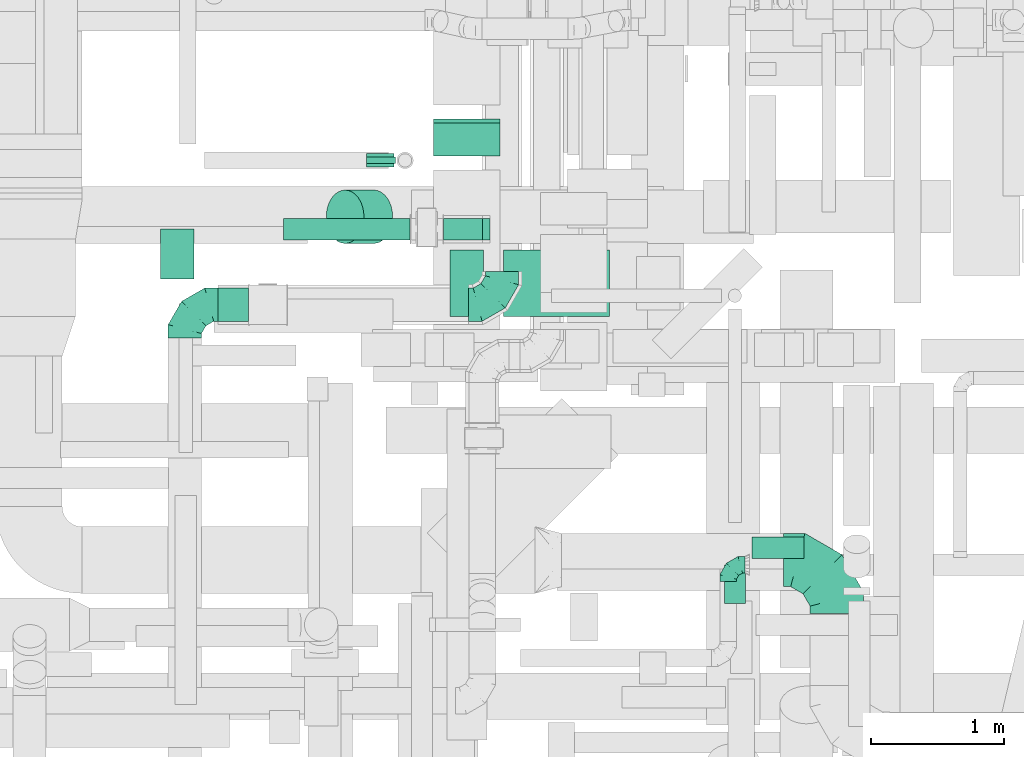
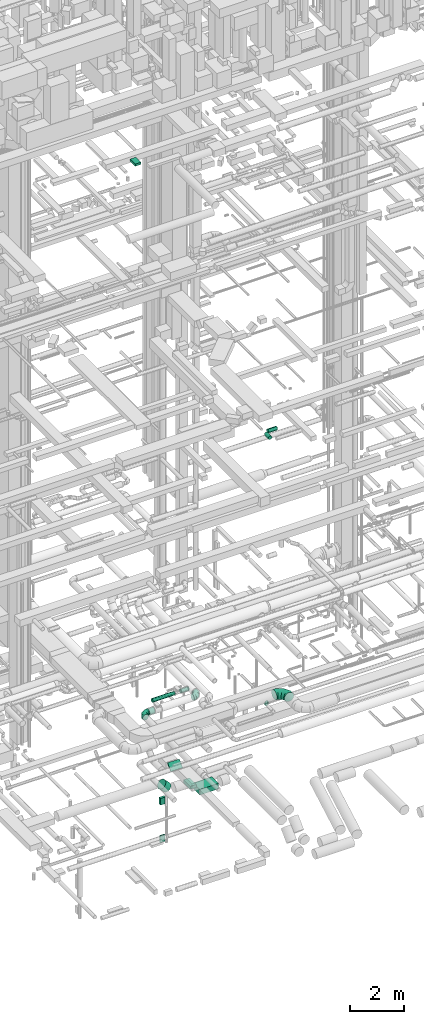
# One storey, part 166 of 337: 12 flow segments, 5 flow fittings.
"""IFC2X3 building model written with IfcOpenShell, lengths in millimetres."""

from ifc_helpers import new_model, entity, si_unit, converted_unit, derived_unit, direction, frame, origin, origin_2d_with_axis, place, context, subcontext, project, spatial, rectangle, circle, extrude, faceted_brep, source, transform, mapped, material, type_object, type_shapes, element, save


model = new_model("IFC2X3")

# Units and contexts
model_context = context("Model", 3, precision=0.01, world=origin(), true_north=direction((6.12303176911189e-17, 1.0)))
body_context = subcontext(model_context, "Body", "Model", "MODEL_VIEW")
ifc_project = project(units=[si_unit("LENGTHUNIT", "METRE", prefix="MILLI"), si_unit("AREAUNIT", "SQUARE_METRE"), si_unit("VOLUMEUNIT", "CUBIC_METRE"), converted_unit("PLANEANGLEUNIT", "DEGREE", entity("IfcRatioMeasure", 0.0174532925199433), si_unit("PLANEANGLEUNIT", "RADIAN"), dimensions=[0, 0, 0, 0, 0, 0, 0]), si_unit("MASSUNIT", "GRAM", prefix="KILO"), derived_unit("MASSDENSITYUNIT", [(si_unit("MASSUNIT", "GRAM", prefix="KILO"), 1), (si_unit("LENGTHUNIT", "METRE"), -3)]), derived_unit("MOMENTOFINERTIAUNIT", [(si_unit("LENGTHUNIT", "METRE"), 4)]), si_unit("TIMEUNIT", "SECOND"), si_unit("FREQUENCYUNIT", "HERTZ"), si_unit("THERMODYNAMICTEMPERATUREUNIT", "DEGREE_CELSIUS"), derived_unit("THERMALTRANSMITTANCEUNIT", [(si_unit("MASSUNIT", "GRAM", prefix="KILO"), 1), (si_unit("THERMODYNAMICTEMPERATUREUNIT", "KELVIN"), -1), (si_unit("TIMEUNIT", "SECOND"), -3)]), derived_unit("VOLUMETRICFLOWRATEUNIT", [(si_unit("LENGTHUNIT", "METRE"), 3), (si_unit("TIMEUNIT", "SECOND"), -1)]), derived_unit("MASSFLOWRATEUNIT", [(si_unit("MASSUNIT", "GRAM", prefix="KILO"), 1), (si_unit("TIMEUNIT", "SECOND"), -1)]), derived_unit("ROTATIONALFREQUENCYUNIT", [(si_unit("TIMEUNIT", "SECOND"), -1)]), si_unit("ELECTRICCURRENTUNIT", "AMPERE"), si_unit("ELECTRICVOLTAGEUNIT", "VOLT"), si_unit("POWERUNIT", "WATT"), si_unit("FORCEUNIT", "NEWTON", prefix="KILO"), si_unit("ILLUMINANCEUNIT", "LUX"), si_unit("LUMINOUSFLUXUNIT", "LUMEN"), si_unit("LUMINOUSINTENSITYUNIT", "CANDELA"), derived_unit("USERDEFINED", [(si_unit("MASSUNIT", "GRAM", prefix="KILO"), -1), (si_unit("LENGTHUNIT", "METRE"), -2), (si_unit("TIMEUNIT", "SECOND"), 3), (si_unit("LUMINOUSFLUXUNIT", "LUMEN"), 1)]), derived_unit("LINEARVELOCITYUNIT", [(si_unit("LENGTHUNIT", "METRE"), 1), (si_unit("TIMEUNIT", "SECOND"), -1)]), si_unit("PRESSUREUNIT", "PASCAL"), derived_unit("USERDEFINED", [(si_unit("LENGTHUNIT", "METRE"), -2), (si_unit("MASSUNIT", "GRAM", prefix="KILO"), 1), (si_unit("TIMEUNIT", "SECOND"), -2)]), derived_unit("LINEARFORCEUNIT", [(si_unit("MASSUNIT", "GRAM", prefix="KILO"), 1), (si_unit("LENGTHUNIT", "METRE"), 1), (si_unit("TIMEUNIT", "SECOND"), -2), (si_unit("LENGTHUNIT", "METRE"), -1)]), derived_unit("PLANARFORCEUNIT", [(si_unit("MASSUNIT", "GRAM", prefix="KILO"), 1), (si_unit("LENGTHUNIT", "METRE"), 1), (si_unit("TIMEUNIT", "SECOND"), -2), (si_unit("LENGTHUNIT", "METRE"), -2)])], contexts=[model_context])

# Site, building, storey
site_placement = place(None, origin())
site = spatial("IfcSite", under=ifc_project, at=site_placement, CompositionType="ELEMENT")
building_placement = place(site_placement, origin())
building = spatial("IfcBuilding", under=site, at=building_placement, CompositionType="ELEMENT")
storey_placement = place(building_placement, origin())
storey = spatial("IfcBuildingStorey", under=building, at=storey_placement, CompositionType="ELEMENT", Elevation=0.0)

# Flow segments
duct_segment_type_1 = type_object("IfcDuctSegmentType", PredefinedType="NOTDEFINED")
flow_segment_1_placement = place(storey_placement, frame((49213.6, 7180.9, -948.55)))
element("IfcFlowSegment", 1, at=flow_segment_1_placement, inside=storey, type_object=duct_segment_type_1, context=body_context, shape_type="SweptSolid", body=[
    extrude(rectangle(XDim=41.888132824211, YDim=350.000000000001, at=origin_2d_with_axis()), frame((0.0, 138.55, 138.55), z_axis=(1.0, 0.0, 0.0), x_axis=(0.0, -0.707106781186528, 0.707106781186567)), (0.0, 0.0, 1.0), 500.000000000016),
])
flow_segment_2_placement = place(storey_placement, frame((49338.6, 5973.55, -1025.0)))
element("IfcFlowSegment", 2, at=flow_segment_2_placement, inside=storey, type_object=duct_segment_type_1, context=body_context, shape_type="SweptSolid", body=[
    extrude(rectangle(XDim=500.0, YDim=250.000000000004, at=origin_2d_with_axis()), frame((125.0, 250.0, 0.0), z_axis=(0.0, 0.0, 1.0), x_axis=(0.0, -1.0, 0.0)), (0.0, 0.0, 1.0), 129.99999999994),
])
flow_segment_3_placement = place(storey_placement, frame((49738.6, 5973.55, -1425.0)))
element("IfcFlowSegment", 3, at=flow_segment_3_placement, inside=storey, type_object=duct_segment_type_1, context=body_context, shape_type="SweptSolid", body=[
    extrude(rectangle(XDim=797.245327746324, YDim=500.0, at=origin_2d_with_axis()), frame((398.62, 250.0, 0.0)), (0.0, 0.0, 1.0), 250.0),
])
flow_segment_4_placement = place(storey_placement, frame((48711.88, 7096.24, -2200.0)))
element("IfcFlowSegment", 4, at=flow_segment_4_placement, inside=storey, type_object=duct_segment_type_1, context=body_context, shape_type="SweptSolid", body=[
    extrude(rectangle(XDim=204.999967249919, YDim=100.0, at=origin_2d_with_axis()), frame((102.5, 50.0, 0.0), z_axis=(0.0, 0.0, 1.0), x_axis=(-1.0, 0.0, 0.0)), (0.0, 0.0, 1.0), 300.0),
])
flow_segment_5_placement = place(storey_placement, frame((48711.74, 7121.24, -3900.0)))
element("IfcFlowSegment", 5, at=flow_segment_5_placement, inside=storey, type_object=duct_segment_type_1, context=body_context, shape_type="SweptSolid", body=[
    extrude(rectangle(XDim=217.638826253178, YDim=49.9999999999995, at=origin_2d_with_axis()), frame((108.82, 25.0, 0.0), z_axis=(0.0, 0.0, 1.0), x_axis=(-1.0, 0.0, 0.0)), (0.0, 0.0, 1.0), 300.0),
])
flow_segment_6_placement = place(storey_placement, frame((47164.17, 6255.79, 27500.0)))
element("IfcFlowSegment", 6, at=flow_segment_6_placement, inside=storey, type_object=duct_segment_type_1, context=body_context, shape_type="SweptSolid", body=[
    extrude(rectangle(XDim=374.199999998891, YDim=250.000000000004, at=origin_2d_with_axis()), frame((125.0, 187.1, 0.0), z_axis=(0.0, 0.0, 1.0), x_axis=(0.0, -1.0, 0.0)), (0.0, 0.0, 1.0), 100.000000000003),
])
duct_segment_type_2 = type_object("IfcDuctSegmentType", PredefinedType="NOTDEFINED")
flow_segment_7_placement = place(storey_placement, frame((51394.41, 3818.15, 15218.4)))
element("IfcFlowSegment", 7, at=flow_segment_7_placement, inside=storey, type_object=duct_segment_type_2, context=body_context, shape_type="SweptSolid", body=[
    extrude(circle(Radius=80.0, at=origin_2d_with_axis()), frame((81.6, 0.0, 81.6), z_axis=(0.0, 1.0, 0.0), x_axis=(1.0, 0.0, 0.0)), (0.0, 0.0, 1.0), 290.000000000021),
])
flow_segment_8_placement = place(storey_placement, frame((51606.01, 4156.55, 15218.4)))
element("IfcFlowSegment", 8, at=flow_segment_8_placement, inside=storey, type_object=duct_segment_type_2, context=body_context, shape_type="SweptSolid", body=[
    extrude(circle(Radius=80.0, at=origin_2d_with_axis()), frame((0.0, 81.6, 81.6), z_axis=(1.0, 0.0, 0.0), x_axis=(0.0, -1.0, 0.0)), (0.0, 0.0, 1.0), 390.000000000015),
])
flow_segment_9_placement = place(storey_placement, frame((47596.39, 5936.56, 2873.4)))
element("IfcFlowSegment", 9, at=flow_segment_9_placement, inside=storey, type_object=duct_segment_type_2, context=body_context, shape_type="SweptSolid", body=[
    extrude(circle(Radius=125.0, at=origin_2d_with_axis()), frame((0.0, 126.6, 126.6), z_axis=(1.0, 0.0, 0.0), x_axis=(0.0, 1.0, 0.0)), (0.0, 0.0, 1.0), 228.606797780962),
])
flow_segment_10_placement = place(storey_placement, frame((48406.52, 6521.49, -1325.86)))
element("IfcFlowSegment", 10, at=flow_segment_10_placement, inside=storey, type_object=duct_segment_type_2, context=body_context, shape_type="SweptSolid", body=[
    extrude(circle(Radius=200.0, at=origin_2d_with_axis()), frame((358.7, 201.6, 143.02), z_axis=(-0.707106781186547, 0.0, 0.707106781186548), x_axis=(0.0, -1.0, 0.0)), (0.0, 0.0, 1.0), 305.025253169392),
])
flow_segment_11_placement = place(storey_placement, frame((48088.92, 6547.83, 2918.4)))
element("IfcFlowSegment", 11, at=flow_segment_11_placement, inside=storey, type_object=duct_segment_type_2, context=body_context, shape_type="SweptSolid", body=[
    extrude(circle(Radius=80.0, at=origin_2d_with_axis()), frame((0.0, 81.6, 81.6), z_axis=(1.0, 0.0, 0.0), x_axis=(0.0, 1.0, 0.0)), (0.0, 0.0, 1.0), 949.341560000641),
])
flow_segment_12_placement = place(storey_placement, frame((49288.27, 6547.83, 2918.4)))
element("IfcFlowSegment", 12, at=flow_segment_12_placement, inside=storey, type_object=duct_segment_type_2, context=body_context, shape_type="SweptSolid", body=[
    extrude(circle(Radius=80.0, at=origin_2d_with_axis()), frame((0.0, 81.6, 81.6), z_axis=(1.0, 0.0, 0.0), x_axis=(0.0, 1.0, 0.0)), (0.0, 0.0, 1.0), 294.275379129593),
])

# Flow fittings
ifc_material = material()
duct_fitting_type_1 = type_object("IfcDuctFittingType", PredefinedType="NOTDEFINED", material=ifc_material)
shared_shape_1 = source(origin(), body_context, "Body", "Brep", [
    faceted_brep([(-250.0, 0.0, -125.0), (-250.0, -32.35, -120.74), (-250.0, -62.5, -108.25), (-250.0, -88.39, -88.39), (-250.0, -108.25, -62.5), (-250.0, -120.74, -32.35), (-250.0, -125.0, 0.0), (-250.0, -120.74, 32.35), (-250.0, -108.25, 62.5), (-250.0, -88.39, 88.39), (-250.0, -62.5, 108.25), (-250.0, -32.35, 120.74), (-250.0, 0.0, 125.0), (-250.0, 32.35, 120.74), (-250.0, 62.5, 108.25), (-250.0, 88.39, 88.39), (-250.0, 108.25, 62.5), (-250.0, 120.74, 32.35), (-250.0, 125.0, 0.0), (-250.0, 120.74, -32.35), (-250.0, 108.25, -62.5), (-250.0, 88.39, -88.39), (-250.0, 62.5, -108.25), (-250.0, 32.35, -120.74), (-191.68, 32.35, 120.74), (-199.76, 62.5, 108.25), (-183.01, 0.0, 125.0), (-206.7, 88.39, 88.39), (-215.37, 120.74, 32.35), (-216.51, 125.0, 0.0), (-212.02, 108.25, 62.5), (-212.02, 108.25, -62.5), (-206.7, 88.39, -88.39), (-215.37, 120.74, -32.35), (-191.68, 32.35, -120.74), (-183.01, 0.0, -125.0), (-199.76, 62.5, -108.25), (-174.34, -32.35, -120.74), (-166.27, -62.5, -108.25), (-159.33, -88.39, -88.39), (-154.01, -108.25, -62.5), (-150.66, -120.74, -32.35), (-149.52, -125.0, 0.0), (-150.66, -120.74, 32.35), (-154.01, -108.25, 62.5), (-159.33, -88.39, 88.39), (-166.27, -62.5, 108.25), (-174.34, -32.35, 120.74), (-90.67, 90.67, 120.74), (-112.74, 112.74, 108.25), (-66.99, 66.99, 125.0), (-131.69, 131.69, 88.39), (-146.23, 146.23, 62.5), (-155.38, 155.38, 32.35), (-158.49, 158.49, 0.0), (-155.38, 155.38, -32.35), (-146.23, 146.23, -62.5), (-131.69, 131.69, -88.39), (-90.67, 90.67, -120.74), (-66.99, 66.99, -125.0), (-112.74, 112.74, -108.25), (-43.3, 43.3, -120.74), (-21.23, 21.23, -108.25), (-2.28, 2.28, -88.39), (12.26, -12.26, -62.5), (21.4, -21.4, -32.35), (24.52, -24.52, 0.0), (21.4, -21.4, 32.35), (12.26, -12.26, 62.5), (-2.28, 2.28, 88.39), (-21.23, 21.23, 108.25), (-43.3, 43.3, 120.74), (-32.35, 191.68, 120.74), (-62.5, 199.76, 108.25), (0.0, 183.01, 125.0), (-88.39, 206.7, 88.39), (-108.25, 212.02, 62.5), (-120.74, 215.37, 32.35), (-125.0, 216.51, 0.0), (-120.74, 215.37, -32.35), (-108.25, 212.02, -62.5), (-88.39, 206.7, -88.39), (-32.35, 191.68, -120.74), (0.0, 183.01, -125.0), (-62.5, 199.76, -108.25), (32.35, 174.34, -120.74), (62.5, 166.27, -108.25), (88.39, 159.33, -88.39), (108.25, 154.01, -62.5), (120.74, 150.66, -32.35), (125.0, 149.52, 0.0), (120.74, 150.66, 32.35), (108.25, 154.01, 62.5), (88.39, 159.33, 88.39), (62.5, 166.27, 108.25), (32.35, 174.34, 120.74), (-32.35, 250.0, -120.74), (-62.5, 250.0, -108.25), (-88.39, 250.0, -88.39), (-108.25, 250.0, -62.5), (-120.74, 250.0, -32.35), (-125.0, 250.0, 0.0), (-120.74, 250.0, 32.35), (-108.25, 250.0, 62.5), (-88.39, 250.0, 88.39), (-62.5, 250.0, 108.25), (-32.35, 250.0, 120.74), (0.0, 250.0, 125.0), (32.35, 250.0, 120.74), (62.5, 250.0, 108.25), (88.39, 250.0, 88.39), (108.25, 250.0, 62.5), (120.74, 250.0, 32.35), (125.0, 250.0, 0.0), (120.74, 250.0, -32.35), (108.25, 250.0, -62.5), (88.39, 250.0, -88.39), (62.5, 250.0, -108.25), (32.35, 250.0, -120.74), (0.0, 250.0, -125.0)], [[[0, 1, 2, 3, 4, 5, 6, 7, 8, 9, 10, 11, 12, 13, 14, 15, 16, 17, 18, 19, 20, 21, 22, 23]], [[24, 25, 14, 13]], [[26, 24, 13, 12]], [[14, 25, 27, 15]], [[28, 29, 18, 17]], [[30, 28, 17, 16]], [[15, 27, 30, 16]], [[20, 31, 32, 21]], [[33, 31, 20, 19]], [[18, 29, 33, 19]], [[34, 35, 0, 23]], [[36, 34, 23, 22]], [[21, 32, 36, 22]], [[1, 0, 35, 37]], [[2, 1, 37, 38]], [[38, 39, 3, 2]], [[5, 4, 40, 41]], [[6, 5, 41, 42]], [[39, 40, 4, 3]], [[6, 42, 43, 7]], [[7, 43, 44, 8]], [[8, 44, 45, 9]], [[9, 45, 46, 10]], [[10, 46, 47, 11]], [[26, 12, 11, 47]], [[48, 49, 25, 24]], [[50, 48, 24, 26]], [[27, 25, 49, 51]], [[52, 53, 28, 30]], [[51, 52, 30, 27]], [[29, 28, 53, 54]], [[55, 56, 31, 33]], [[54, 55, 33, 29]], [[32, 31, 56, 57]], [[58, 59, 35, 34]], [[60, 58, 34, 36]], [[57, 60, 36, 32]], [[37, 35, 59, 61]], [[38, 37, 61, 62]], [[39, 38, 62, 63]], [[41, 40, 64, 65]], [[42, 41, 65, 66]], [[63, 64, 40, 39]], [[43, 42, 66, 67]], [[44, 43, 67, 68]], [[68, 69, 45, 44]], [[46, 45, 69, 70]], [[47, 46, 70, 71]], [[26, 47, 71, 50]], [[72, 73, 49, 48]], [[74, 72, 48, 50]], [[51, 49, 73, 75]], [[76, 77, 53, 52]], [[75, 76, 52, 51]], [[54, 53, 77, 78]], [[79, 80, 56, 55]], [[78, 79, 55, 54]], [[57, 56, 80, 81]], [[82, 83, 59, 58]], [[84, 82, 58, 60]], [[81, 84, 60, 57]], [[61, 59, 83, 85]], [[62, 61, 85, 86]], [[63, 62, 86, 87]], [[65, 64, 88, 89]], [[66, 65, 89, 90]], [[87, 88, 64, 63]], [[67, 66, 90, 91]], [[68, 67, 91, 92]], [[92, 93, 69, 68]], [[70, 69, 93, 94]], [[71, 70, 94, 95]], [[50, 71, 95, 74]], [[96, 97, 98, 99, 100, 101, 102, 103, 104, 105, 106, 107, 108, 109, 110, 111, 112, 113, 114, 115, 116, 117, 118, 119]], [[72, 74, 107, 106]], [[73, 72, 106, 105]], [[75, 73, 105, 104]], [[77, 76, 103, 102]], [[78, 77, 102, 101]], [[75, 104, 103, 76]], [[78, 101, 100, 79]], [[79, 100, 99, 80]], [[80, 99, 98, 81]], [[84, 97, 96, 82]], [[82, 96, 119, 83]], [[84, 81, 98, 97]], [[83, 119, 118, 85]], [[85, 118, 117, 86]], [[116, 87, 86, 117]], [[88, 115, 114, 89]], [[89, 114, 113, 90]], [[115, 88, 87, 116]], [[91, 90, 113, 112]], [[92, 91, 112, 111]], [[111, 110, 93, 92]], [[95, 94, 109, 108]], [[74, 95, 108, 107]], [[110, 109, 94, 93]]]),
])
type_shapes(duct_fitting_type_1, [shared_shape_1])
flow_fitting_1_placement = place(storey_placement, frame((47346.39, 6063.16, 3000.0), z_axis=(0.0, 0.0, 1.0), x_axis=(-1.0, 0.0, 0.0)))
element("IfcFlowFitting", 13, at=flow_fitting_1_placement, inside=storey, type_object=duct_fitting_type_1, material=ifc_material, context=body_context, shape_type="MappedRepresentation", body=[
    mapped(shared_shape_1, transform((0.0, 0.0, 0.0), scale=1.0)),
])
flow_fitting_2_placement = place(storey_placement, frame((49727.54, 6063.16, 3000.0)))
element("IfcFlowFitting", 14, at=flow_fitting_2_placement, inside=storey, type_object=duct_fitting_type_1, material=ifc_material, context=body_context, shape_type="MappedRepresentation", body=[
    mapped(shared_shape_1, transform((0.0, 0.0, 0.0), scale=1.0)),
])
duct_fitting_type_2 = type_object("IfcDuctFittingType", PredefinedType="NOTDEFINED", material=ifc_material)
shared_shape_2 = source(origin(), body_context, "Body", "Brep", [
    faceted_brep([(-125.0, 0.0, -62.5), (-125.0, -16.18, -60.37), (-125.0, -31.25, -54.13), (-125.0, -44.19, -44.19), (-125.0, -54.13, -31.25), (-125.0, -60.37, -16.18), (-125.0, -62.5, 0.0), (-125.0, -60.37, 16.18), (-125.0, -54.13, 31.25), (-125.0, -44.19, 44.19), (-125.0, -31.25, 54.13), (-125.0, -16.18, 60.37), (-125.0, 0.0, 62.5), (-125.0, 16.18, 60.37), (-125.0, 31.25, 54.13), (-125.0, 44.19, 44.19), (-125.0, 54.13, 31.25), (-125.0, 60.37, 16.18), (-125.0, 62.5, 0.0), (-125.0, 60.37, -16.18), (-125.0, 54.13, -31.25), (-125.0, 44.19, -44.19), (-125.0, 31.25, -54.13), (-125.0, 16.18, -60.37), (-95.84, 16.18, 60.37), (-99.88, 31.25, 54.13), (-91.51, 0.0, 62.5), (-103.35, 44.19, 44.19), (-107.68, 60.37, 16.18), (-108.25, 62.5, 0.0), (-106.01, 54.13, 31.25), (-106.01, 54.13, -31.25), (-103.35, 44.19, -44.19), (-107.68, 60.37, -16.18), (-95.84, 16.18, -60.37), (-91.51, 0.0, -62.5), (-99.88, 31.25, -54.13), (-87.17, -16.18, -60.37), (-83.13, -31.25, -54.13), (-79.66, -44.19, -44.19), (-77.0, -54.13, -31.25), (-75.33, -60.37, -16.18), (-74.76, -62.5, 0.0), (-75.33, -60.37, 16.18), (-77.0, -54.13, 31.25), (-79.66, -44.19, 44.19), (-83.13, -31.25, 54.13), (-87.17, -16.18, 60.37), (-45.34, 45.34, 60.37), (-56.37, 56.37, 54.13), (-33.49, 33.49, 62.5), (-65.85, 65.85, 44.19), (-73.12, 73.12, 31.25), (-77.69, 77.69, 16.18), (-79.25, 79.25, 0.0), (-77.69, 77.69, -16.18), (-73.12, 73.12, -31.25), (-65.85, 65.85, -44.19), (-45.34, 45.34, -60.37), (-33.49, 33.49, -62.5), (-56.37, 56.37, -54.13), (-21.65, 21.65, -60.37), (-10.62, 10.62, -54.13), (-1.14, 1.14, -44.19), (6.13, -6.13, -31.25), (10.7, -10.7, -16.18), (12.26, -12.26, 0.0), (10.7, -10.7, 16.18), (6.13, -6.13, 31.25), (-1.14, 1.14, 44.19), (-10.62, 10.62, 54.13), (-21.65, 21.65, 60.37), (-16.18, 95.84, 60.37), (-31.25, 99.88, 54.13), (0.0, 91.51, 62.5), (-44.19, 103.35, 44.19), (-54.13, 106.01, 31.25), (-60.37, 107.68, 16.18), (-62.5, 108.25, 0.0), (-60.37, 107.68, -16.18), (-54.13, 106.01, -31.25), (-44.19, 103.35, -44.19), (-16.18, 95.84, -60.37), (0.0, 91.51, -62.5), (-31.25, 99.88, -54.13), (16.18, 87.17, -60.37), (31.25, 83.13, -54.13), (44.19, 79.66, -44.19), (54.13, 77.0, -31.25), (60.37, 75.33, -16.18), (62.5, 74.76, 0.0), (60.37, 75.33, 16.18), (54.13, 77.0, 31.25), (44.19, 79.66, 44.19), (31.25, 83.13, 54.13), (16.18, 87.17, 60.37), (-16.18, 125.0, -60.37), (-31.25, 125.0, -54.13), (-44.19, 125.0, -44.19), (-54.13, 125.0, -31.25), (-60.37, 125.0, -16.18), (-62.5, 125.0, 0.0), (-60.37, 125.0, 16.18), (-54.13, 125.0, 31.25), (-44.19, 125.0, 44.19), (-31.25, 125.0, 54.13), (-16.18, 125.0, 60.37), (0.0, 125.0, 62.5), (16.18, 125.0, 60.37), (31.25, 125.0, 54.13), (44.19, 125.0, 44.19), (54.13, 125.0, 31.25), (60.37, 125.0, 16.18), (62.5, 125.0, 0.0), (60.37, 125.0, -16.18), (54.13, 125.0, -31.25), (44.19, 125.0, -44.19), (31.25, 125.0, -54.13), (16.18, 125.0, -60.37), (0.0, 125.0, -62.5)], [[[0, 1, 2, 3, 4, 5, 6, 7, 8, 9, 10, 11, 12, 13, 14, 15, 16, 17, 18, 19, 20, 21, 22, 23]], [[24, 25, 14, 13]], [[26, 24, 13, 12]], [[14, 25, 27, 15]], [[28, 29, 18, 17]], [[30, 28, 17, 16]], [[15, 27, 30, 16]], [[20, 31, 32, 21]], [[33, 31, 20, 19]], [[18, 29, 33, 19]], [[34, 35, 0, 23]], [[36, 34, 23, 22]], [[21, 32, 36, 22]], [[1, 0, 35, 37]], [[2, 1, 37, 38]], [[38, 39, 3, 2]], [[5, 4, 40, 41]], [[6, 5, 41, 42]], [[39, 40, 4, 3]], [[6, 42, 43, 7]], [[7, 43, 44, 8]], [[45, 9, 8, 44]], [[9, 45, 46, 10]], [[10, 46, 47, 11]], [[26, 12, 11, 47]], [[48, 49, 25, 24]], [[50, 48, 24, 26]], [[27, 25, 49, 51]], [[52, 53, 28, 30]], [[51, 52, 30, 27]], [[29, 28, 53, 54]], [[55, 56, 31, 33]], [[54, 55, 33, 29]], [[57, 32, 31, 56]], [[58, 59, 35, 34]], [[60, 58, 34, 36]], [[57, 60, 36, 32]], [[37, 35, 59, 61]], [[38, 37, 61, 62]], [[39, 38, 62, 63]], [[41, 40, 64, 65]], [[42, 41, 65, 66]], [[63, 64, 40, 39]], [[43, 42, 66, 67]], [[44, 43, 67, 68]], [[68, 69, 45, 44]], [[46, 45, 69, 70]], [[47, 46, 70, 71]], [[26, 47, 71, 50]], [[72, 73, 49, 48]], [[74, 72, 48, 50]], [[51, 49, 73, 75]], [[76, 77, 53, 52]], [[75, 76, 52, 51]], [[54, 53, 77, 78]], [[79, 80, 56, 55]], [[78, 79, 55, 54]], [[81, 57, 56, 80]], [[82, 83, 59, 58]], [[84, 82, 58, 60]], [[81, 84, 60, 57]], [[61, 59, 83, 85]], [[62, 61, 85, 86]], [[63, 62, 86, 87]], [[65, 64, 88, 89]], [[66, 65, 89, 90]], [[87, 88, 64, 63]], [[67, 66, 90, 91]], [[68, 67, 91, 92]], [[92, 93, 69, 68]], [[70, 69, 93, 94]], [[71, 70, 94, 95]], [[50, 71, 95, 74]], [[96, 97, 98, 99, 100, 101, 102, 103, 104, 105, 106, 107, 108, 109, 110, 111, 112, 113, 114, 115, 116, 117, 118, 119]], [[72, 74, 107, 106]], [[73, 72, 106, 105]], [[75, 73, 105, 104]], [[77, 76, 103, 102]], [[78, 77, 102, 101]], [[75, 104, 103, 76]], [[78, 101, 100, 79]], [[79, 100, 99, 80]], [[80, 99, 98, 81]], [[96, 119, 83, 82]], [[97, 96, 82, 84]], [[84, 81, 98, 97]], [[83, 119, 118, 85]], [[85, 118, 117, 86]], [[116, 87, 86, 117]], [[88, 115, 114, 89]], [[89, 114, 113, 90]], [[115, 88, 87, 116]], [[91, 90, 113, 112]], [[92, 91, 112, 111]], [[111, 110, 93, 92]], [[95, 94, 109, 108]], [[74, 95, 108, 107]], [[110, 109, 94, 93]]]),
])
type_shapes(duct_fitting_type_2, [shared_shape_2])
flow_fitting_3_placement = place(storey_placement, frame((51425.0, 4110.29, 3250.0), z_axis=(0.0, 0.0, 1.0), x_axis=(-1.0, 0.0, 0.0)))
element("IfcFlowFitting", 15, at=flow_fitting_3_placement, inside=storey, type_object=duct_fitting_type_2, material=ifc_material, context=body_context, shape_type="MappedRepresentation", body=[
    mapped(shared_shape_2, transform((0.0, 0.0, 0.0), scale=1.0)),
])
duct_fitting_type_3 = type_object("IfcDuctFittingType", PredefinedType="NOTDEFINED", material=ifc_material)
shared_shape_3 = source(origin(), body_context, "Body", "Brep", [
    faceted_brep([(-400.0, 0.0, -200.0), (-400.0, -44.5, -194.99), (-400.0, -86.78, -180.19), (-400.0, -124.7, -156.37), (-400.0, -156.37, -124.7), (-400.0, -180.19, -86.78), (-400.0, -194.99, -44.5), (-400.0, -200.0, 0.0), (-400.0, -194.99, 44.5), (-400.0, -180.19, 86.78), (-400.0, -156.37, 124.7), (-400.0, -124.7, 156.37), (-400.0, -86.78, 180.19), (-400.0, -44.5, 194.99), (-400.0, 0.0, 200.0), (-400.0, 44.5, 194.99), (-400.0, 86.78, 180.19), (-400.0, 124.7, 156.37), (-400.0, 156.37, 124.7), (-400.0, 180.19, 86.78), (-400.0, 194.99, 44.5), (-400.0, 200.0, 0.0), (-400.0, 194.99, -44.5), (-400.0, 180.19, -86.78), (-400.0, 156.37, -124.7), (-400.0, 124.7, -156.37), (-400.0, 86.78, -180.19), (-400.0, 44.5, -194.99), (-292.82, 0.0, 200.0), (-304.75, 44.5, 194.99), (-316.07, 86.78, 180.19), (-326.23, 124.7, 156.37), (-334.72, 156.37, 124.7), (-341.1, 180.19, 86.78), (-345.07, 194.99, 44.5), (-346.41, 200.0, 0.0), (-345.07, 194.99, -44.5), (-341.1, 180.19, -86.78), (-334.72, 156.37, -124.7), (-326.23, 124.7, -156.37), (-316.07, 86.78, -180.19), (-304.75, 44.5, -194.99), (-292.82, 0.0, -200.0), (-280.9, -44.5, -194.99), (-269.57, -86.78, -180.19), (-259.41, -124.7, -156.37), (-250.92, -156.37, -124.7), (-244.54, -180.19, -86.78), (-240.57, -194.99, -44.5), (-239.23, -200.0, 0.0), (-240.57, -194.99, 44.5), (-244.54, -180.19, 86.78), (-250.92, -156.37, 124.7), (-259.41, -124.7, 156.37), (-269.57, -86.78, 180.19), (-280.9, -44.5, 194.99), (-107.18, 107.18, 200.0), (-139.76, 139.76, 194.99), (-170.7, 170.7, 180.19), (-198.46, 198.46, 156.37), (-221.65, 221.65, 124.7), (-239.09, 239.09, 86.78), (-249.92, 249.92, 44.5), (-253.59, 253.59, 0.0), (-249.92, 249.92, -44.5), (-239.09, 239.09, -86.78), (-221.65, 221.65, -124.7), (-198.46, 198.46, -156.37), (-170.7, 170.7, -180.19), (-139.76, 139.76, -194.99), (-107.18, 107.18, -200.0), (-74.6, 74.6, -194.99), (-43.65, 43.65, -180.19), (-15.89, 15.89, -156.37), (7.29, -7.29, -124.7), (24.73, -24.73, -86.78), (35.56, -35.56, -44.5), (39.23, -39.23, 0.0), (35.56, -35.56, 44.5), (24.73, -24.73, 86.78), (7.29, -7.29, 124.7), (-15.89, 15.89, 156.37), (-43.65, 43.65, 180.19), (-74.6, 74.6, 194.99), (0.0, 292.82, 200.0), (-44.5, 304.75, 194.99), (-86.78, 316.07, 180.19), (-124.7, 326.23, 156.37), (-156.37, 334.72, 124.7), (-180.19, 341.1, 86.78), (-194.99, 345.07, 44.5), (-200.0, 346.41, 0.0), (-194.99, 345.07, -44.5), (-180.19, 341.1, -86.78), (-156.37, 334.72, -124.7), (-124.7, 326.23, -156.37), (-86.78, 316.07, -180.19), (-44.5, 304.75, -194.99), (0.0, 292.82, -200.0), (44.5, 280.9, -194.99), (86.78, 269.57, -180.19), (124.7, 259.41, -156.37), (156.37, 250.92, -124.7), (180.19, 244.54, -86.78), (194.99, 240.57, -44.5), (200.0, 239.23, 0.0), (194.99, 240.57, 44.5), (180.19, 244.54, 86.78), (156.37, 250.92, 124.7), (124.7, 259.41, 156.37), (86.78, 269.57, 180.19), (44.5, 280.9, 194.99), (-44.5, 400.0, -194.99), (-86.78, 400.0, -180.19), (-124.7, 400.0, -156.37), (-156.37, 400.0, -124.7), (-180.19, 400.0, -86.78), (-194.99, 400.0, -44.5), (-200.0, 400.0, 0.0), (-194.99, 400.0, 44.5), (-180.19, 400.0, 86.78), (-156.37, 400.0, 124.7), (-124.7, 400.0, 156.37), (-86.78, 400.0, 180.19), (-44.5, 400.0, 194.99), (0.0, 400.0, 200.0), (44.5, 400.0, 194.99), (86.78, 400.0, 180.19), (124.7, 400.0, 156.37), (156.37, 400.0, 124.7), (180.19, 400.0, 86.78), (194.99, 400.0, 44.5), (200.0, 400.0, 0.0), (194.99, 400.0, -44.5), (180.19, 400.0, -86.78), (156.37, 400.0, -124.7), (124.7, 400.0, -156.37), (86.78, 400.0, -180.19), (44.5, 400.0, -194.99), (0.0, 400.0, -200.0)], [[[0, 1, 2, 3, 4, 5, 6, 7, 8, 9, 10, 11, 12, 13, 14, 15, 16, 17, 18, 19, 20, 21, 22, 23, 24, 25, 26, 27]], [[28, 29, 15, 14]], [[30, 31, 17, 16]], [[29, 30, 16, 15]], [[31, 32, 18, 17]], [[32, 33, 19, 18]], [[34, 35, 21, 20]], [[33, 34, 20, 19]], [[35, 36, 22, 21]], [[37, 38, 24, 23]], [[36, 37, 23, 22]], [[38, 39, 25, 24]], [[39, 40, 26, 25]], [[41, 42, 0, 27]], [[40, 41, 27, 26]], [[1, 0, 42, 43]], [[43, 44, 2, 1]], [[45, 3, 2, 44]], [[45, 46, 4, 3]], [[5, 4, 46, 47]], [[47, 48, 6, 5]], [[49, 7, 6, 48]], [[7, 49, 50, 8]], [[8, 50, 51, 9]], [[9, 51, 52, 10]], [[52, 53, 11, 10]], [[11, 53, 54, 12]], [[12, 54, 55, 13]], [[13, 55, 28, 14]], [[56, 57, 29, 28]], [[58, 59, 31, 30]], [[57, 58, 30, 29]], [[59, 60, 32, 31]], [[60, 61, 33, 32]], [[62, 63, 35, 34]], [[61, 62, 34, 33]], [[63, 64, 36, 35]], [[65, 66, 38, 37]], [[64, 65, 37, 36]], [[66, 67, 39, 38]], [[67, 68, 40, 39]], [[69, 70, 42, 41]], [[68, 69, 41, 40]], [[43, 42, 70, 71]], [[71, 72, 44, 43]], [[73, 45, 44, 72]], [[73, 74, 46, 45]], [[47, 46, 74, 75]], [[75, 76, 48, 47]], [[77, 49, 48, 76]], [[50, 49, 77, 78]], [[51, 50, 78, 79]], [[52, 51, 79, 80]], [[80, 81, 53, 52]], [[54, 53, 81, 82]], [[55, 54, 82, 83]], [[28, 55, 83, 56]], [[84, 85, 57, 56]], [[86, 87, 59, 58]], [[85, 86, 58, 57]], [[87, 88, 60, 59]], [[88, 89, 61, 60]], [[90, 91, 63, 62]], [[89, 90, 62, 61]], [[91, 92, 64, 63]], [[93, 94, 66, 65]], [[92, 93, 65, 64]], [[94, 95, 67, 66]], [[95, 96, 68, 67]], [[97, 98, 70, 69]], [[96, 97, 69, 68]], [[71, 70, 98, 99]], [[99, 100, 72, 71]], [[101, 73, 72, 100]], [[101, 102, 74, 73]], [[75, 74, 102, 103]], [[103, 104, 76, 75]], [[105, 77, 76, 104]], [[78, 77, 105, 106]], [[79, 78, 106, 107]], [[80, 79, 107, 108]], [[108, 109, 81, 80]], [[82, 81, 109, 110]], [[83, 82, 110, 111]], [[56, 83, 111, 84]], [[112, 113, 114, 115, 116, 117, 118, 119, 120, 121, 122, 123, 124, 125, 126, 127, 128, 129, 130, 131, 132, 133, 134, 135, 136, 137, 138, 139]], [[85, 84, 125, 124]], [[86, 85, 124, 123]], [[87, 86, 123, 122]], [[122, 121, 88, 87]], [[89, 88, 121, 120]], [[90, 89, 120, 119]], [[91, 90, 119, 118]], [[91, 118, 117, 92]], [[92, 117, 116, 93]], [[93, 116, 115, 94]], [[115, 114, 95, 94]], [[95, 114, 113, 96]], [[96, 113, 112, 97]], [[97, 112, 139, 98]], [[98, 139, 138, 99]], [[99, 138, 137, 100]], [[100, 137, 136, 101]], [[136, 135, 102, 101]], [[102, 135, 134, 103]], [[103, 134, 133, 104]], [[104, 133, 132, 105]], [[106, 105, 132, 131]], [[107, 106, 131, 130]], [[108, 107, 130, 129]], [[129, 128, 109, 108]], [[110, 109, 128, 127]], [[111, 110, 127, 126]], [[84, 111, 126, 125]]]),
])
type_shapes(duct_fitting_type_3, [shared_shape_3])
flow_fitting_4_placement = place(storey_placement, frame((52240.84, 4146.24, 3450.0), z_axis=(0.0, 0.0, 1.0), x_axis=(0.0, 1.0, 0.0)))
element("IfcFlowFitting", 16, at=flow_fitting_4_placement, inside=storey, type_object=duct_fitting_type_3, material=ifc_material, context=body_context, shape_type="MappedRepresentation", body=[
    mapped(shared_shape_3, transform((0.0, 0.0, 0.0), scale=1.0)),
])
duct_fitting_type_4 = type_object("IfcDuctFittingType", PredefinedType="NOTDEFINED", material=ifc_material)
shared_shape_4 = source(origin(), body_context, "Body", "Brep", [
    faceted_brep([(20.0, 20.71, -77.27), (20.0, 40.0, -69.28), (20.0, 56.57, -56.57), (20.0, 69.28, -40.0), (20.0, 77.27, -20.71), (20.0, 80.0, 0.0), (20.0, 77.27, 20.71), (20.0, 69.28, 40.0), (20.0, 56.57, 56.57), (20.0, 40.0, 69.28), (20.0, 20.71, 77.27), (20.0, 0.0, 80.0), (20.0, -20.71, 77.27), (20.0, -40.0, 69.28), (20.0, -56.57, 56.57), (20.0, -69.28, 40.0), (20.0, -77.27, 20.71), (20.0, -80.0, 0.0), (20.0, -77.27, -20.71), (20.0, -69.28, -40.0), (20.0, -56.57, -56.57), (20.0, -40.0, -69.28), (20.0, -20.71, -77.27), (20.0, 0.0, -80.0), (0.0, 0.0, 80.0), (0.0, 20.71, 77.27), (-35.05, 20.71, 77.27), (-35.05, 0.0, 80.0), (0.0, 40.0, 69.28), (-35.05, 40.0, 69.28), (0.0, 56.57, 56.57), (-35.05, 56.57, 56.57), (0.0, 69.28, 40.0), (0.0, 77.27, 20.71), (-35.05, 77.27, 20.71), (-35.05, 69.28, 40.0), (0.0, 80.0, 0.0), (-35.05, 80.0, 0.0), (0.0, 77.27, -20.71), (-35.05, 77.27, -20.71), (0.0, 69.28, -40.0), (-35.05, 69.28, -40.0), (0.0, 56.57, -56.57), (-35.05, 56.57, -56.57), (0.0, 40.0, -69.28), (0.0, 20.71, -77.27), (-35.05, 20.71, -77.27), (-35.05, 40.0, -69.28), (0.0, 0.0, -80.0), (-35.05, 0.0, -80.0), (0.0, -20.71, -77.27), (-35.05, -20.71, -77.27), (0.0, -40.0, -69.28), (-35.05, -40.0, -69.28), (0.0, -56.57, -56.57), (-35.05, -56.57, -56.57), (0.0, -69.28, -40.0), (0.0, -77.27, -20.71), (-35.05, -77.27, -20.71), (-35.05, -69.28, -40.0), (0.0, -80.0, 0.0), (-35.05, -80.0, 0.0), (0.0, -77.27, 20.71), (-35.05, -77.27, 20.71), (0.0, -69.28, 40.0), (-35.05, -69.28, 40.0), (0.0, -56.57, 56.57), (-35.05, -56.57, 56.57), (0.0, -40.0, 69.28), (0.0, -20.71, 77.27), (-35.05, -20.71, 77.27), (-35.05, -40.0, 69.28)], [[[0, 1, 2, 3, 4, 5, 6, 7, 8, 9, 10, 11, 12, 13, 14, 15, 16, 17, 18, 19, 20, 21, 22, 23]], [[24, 11, 10, 25, 26, 27]], [[25, 10, 9, 28, 29, 26]], [[28, 9, 8, 30, 31, 29]], [[32, 7, 6, 33, 34, 35]], [[33, 6, 5, 36, 37, 34]], [[30, 8, 7, 32, 35, 31]], [[36, 5, 4, 38, 39, 37]], [[38, 4, 3, 40, 41, 39]], [[40, 3, 2, 42, 43, 41]], [[44, 1, 0, 45, 46, 47]], [[45, 0, 23, 48, 49, 46]], [[42, 2, 1, 44, 47, 43]], [[48, 23, 22, 50, 51, 49]], [[50, 22, 21, 52, 53, 51]], [[52, 21, 20, 54, 55, 53]], [[56, 19, 18, 57, 58, 59]], [[57, 18, 17, 60, 61, 58]], [[54, 20, 19, 56, 59, 55]], [[60, 17, 16, 62, 63, 61]], [[62, 16, 15, 64, 65, 63]], [[64, 15, 14, 66, 67, 65]], [[68, 13, 12, 69, 70, 71]], [[69, 12, 11, 24, 27, 70]], [[66, 14, 13, 68, 71, 67]], [[49, 51, 53, 55, 59, 58, 61, 63, 65, 67, 71, 70, 27, 26, 29, 31, 35, 34, 37, 39, 41, 43, 47, 46]]]),
])
type_shapes(duct_fitting_type_4, [shared_shape_4])
flow_fitting_5_placement = place(storey_placement, frame((49602.54, 6629.42, 3000.0), z_axis=(0.0, 0.0, -1.0), x_axis=(-1.0, 0.0, 0.0)))
element("IfcFlowFitting", 17, at=flow_fitting_5_placement, inside=storey, type_object=duct_fitting_type_4, material=ifc_material, context=body_context, shape_type="MappedRepresentation", body=[
    mapped(shared_shape_4, transform((0.0, 0.0, 0.0), scale=1.0)),
])

save(model, "model.ifc")
